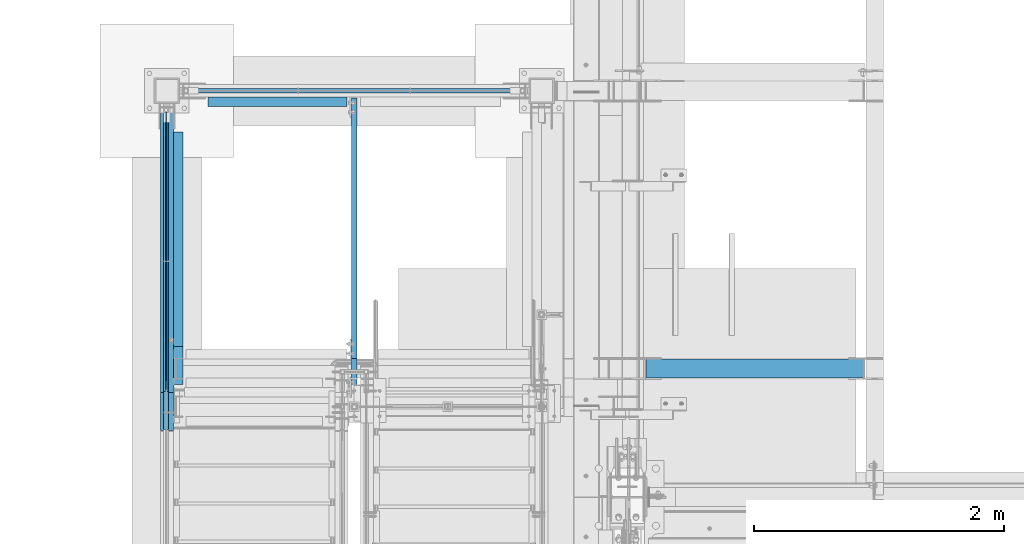
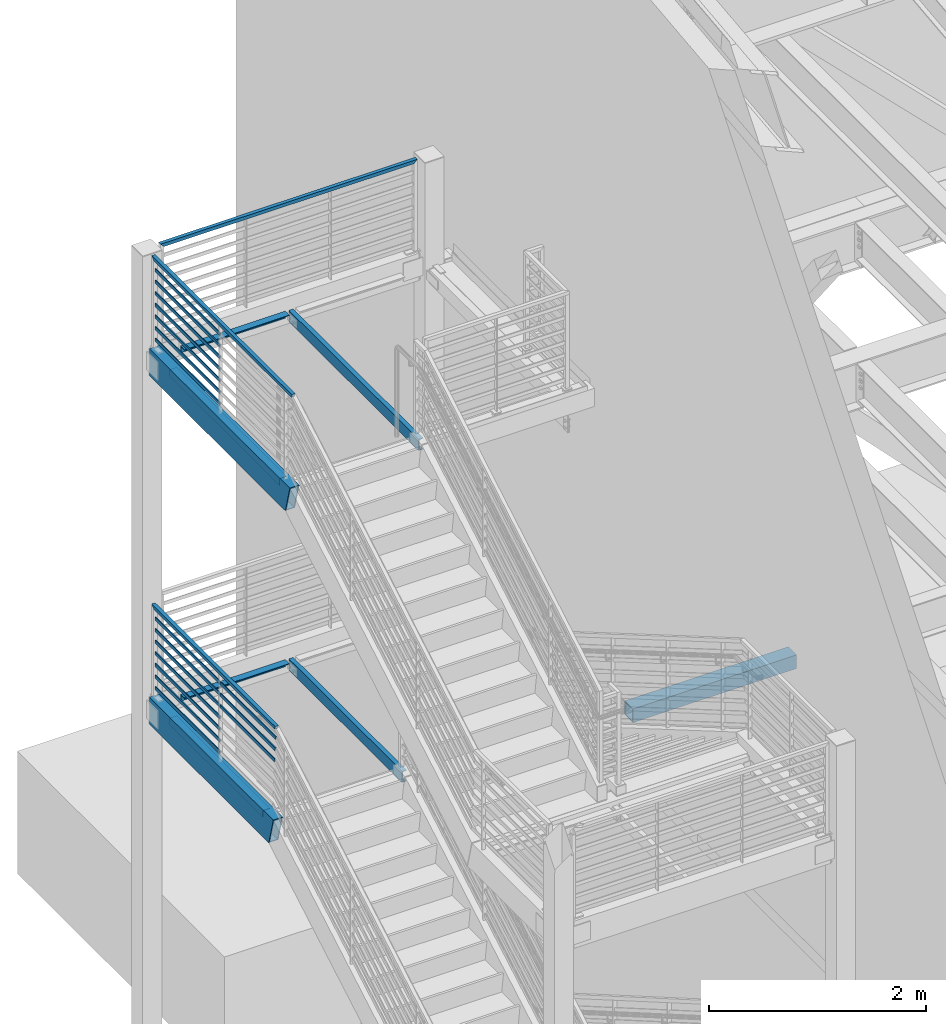
# One storey, part 764 of 1179: 29 beams, 10 elements without a shape of their own.
"""IFC2X3 building model written with IfcOpenShell, lengths in millimetres."""

from ifc_helpers import new_model, si_unit, frame, origin_with_axes, place, context, subcontext, project, spatial, faceted_brep, material, type_object, element, aggregate, save


model = new_model("IFC2X3")

# Units and contexts
model_context = context("Model", 3, precision=1e-05, world=origin_with_axes())
body_context = subcontext(model_context, "Body", "Model", "MODEL_VIEW")
ifc_project = project(units=[si_unit("LENGTHUNIT", "METRE", prefix="MILLI"), si_unit("AREAUNIT", "SQUARE_METRE"), si_unit("VOLUMEUNIT", "CUBIC_METRE"), si_unit("MASSUNIT", "GRAM", prefix="KILO"), si_unit("TIMEUNIT", "SECOND"), si_unit("PLANEANGLEUNIT", "RADIAN"), si_unit("SOLIDANGLEUNIT", "STERADIAN"), si_unit("THERMODYNAMICTEMPERATUREUNIT", "DEGREE_CELSIUS"), si_unit("LUMINOUSINTENSITYUNIT", "LUMEN")], contexts=[model_context])

# Site, building, storey
site_placement = place(None, origin_with_axes())
site = spatial("IfcSite", under=ifc_project, at=site_placement, CompositionType="ELEMENT")
building_placement = place(site_placement, origin_with_axes())
building = spatial("IfcBuilding", under=site, at=building_placement, Name="Undefined", CompositionType="ELEMENT")
storey_placement = place(building_placement, origin_with_axes())
storey = spatial("IfcBuildingStorey", under=building, at=storey_placement, Name="Undefined", CompositionType="ELEMENT", Elevation=0.0)

# Assembly, beams
assembly_1_placement = place(storey_placement, origin_with_axes())
assembly_1 = element("IfcElementAssembly", 1, at=assembly_1_placement, inside=storey, Name="GUARDRAIL", AssemblyPlace="NOTDEFINED", PredefinedType="RIGID_FRAME")
ifc_material_1 = material(Name="STEEL/A36")
beam_type_1 = type_object("IfcBeamType", PredefinedType="NOTDEFINED")
beam_1_placement = place(assembly_1_placement, frame((-3257.54999923555, 37490.4, 8305.78812688397), z_axis=(0.0, 0.0, 1.0), x_axis=(0.0, -1.0, 0.0)))
beam_1 = element("IfcBeam", 2, at=beam_1_placement, type_object=beam_type_1, material=ifc_material_1, Name="PLATE", context=body_context, shape_type="Brep", body=[
    faceted_brep([(19.0499992371956, 4.76249999999709, -19.0499999999993), (19.0499992371956, 4.76249999999709, 19.0499999999993), (1205.97083333334, 4.76249999999982, 19.0499999999993), (1205.97083333334, 4.76249999999982, -19.0499999999993), (19.0499992371956, -4.76249999999709, 19.0499999999993), (1205.97083333334, -4.76249999999982, 19.0499999999993), (19.0499992371956, -4.76249999999709, -19.0499999999993), (1205.97083333334, -4.76249999999982, -19.0499999999993)], [[[0, 1, 2, 3]], [[1, 4, 5, 2]], [[4, 6, 7, 5]], [[6, 0, 3, 7]], [[5, 7, 3, 2]], [[6, 4, 1, 0]]]),
])
beam_2_placement = place(assembly_1_placement, frame((-3257.54999923555, 37490.4, 8435.96312688397), z_axis=(0.0, 0.0, 1.0), x_axis=(0.0, -1.0, 0.0)))
beam_2 = element("IfcBeam", 3, at=beam_2_placement, type_object=beam_type_1, material=ifc_material_1, Name="PLATE", context=body_context, shape_type="Brep", body=[
    faceted_brep([(19.0499992371956, 4.76249999999709, -19.0499999999993), (19.0499992371956, 4.76249999999709, 19.0499999999993), (1205.97083333334, 4.76249999999982, 19.0499999999993), (1205.97083333334, 4.76249999999982, -19.0499999999993), (19.0499992371956, -4.76249999999709, 19.0499999999993), (1205.97083333334, -4.76249999999982, 19.0499999999993), (19.0499992371956, -4.76249999999709, -19.0499999999993), (1205.97083333334, -4.76249999999982, -19.0499999999993)], [[[0, 1, 2, 3]], [[1, 4, 5, 2]], [[4, 6, 7, 5]], [[6, 0, 3, 7]], [[5, 7, 3, 2]], [[6, 4, 1, 0]]]),
])
beam_3_placement = place(assembly_1_placement, frame((-3257.54999923555, 37490.4, 8566.13812688397), z_axis=(0.0, 0.0, 1.0), x_axis=(0.0, -1.0, 0.0)))
beam_3 = element("IfcBeam", 4, at=beam_3_placement, type_object=beam_type_1, material=ifc_material_1, Name="PLATE", context=body_context, shape_type="Brep", body=[
    faceted_brep([(19.0499992371956, 4.76249999999709, -19.0499999999993), (19.0499992371956, 4.76249999999709, 19.0499999999993), (1205.97083333334, 4.76249999999982, 19.0499999999993), (1205.97083333334, 4.76249999999982, -19.0499999999993), (19.0499992371956, -4.76249999999709, 19.0499999999993), (1205.97083333334, -4.76249999999982, 19.0499999999993), (19.0499992371956, -4.76249999999709, -19.0499999999993), (1205.97083333334, -4.76249999999982, -19.0499999999993)], [[[0, 1, 2, 3]], [[1, 4, 5, 2]], [[4, 6, 7, 5]], [[6, 0, 3, 7]], [[5, 7, 3, 2]], [[6, 4, 1, 0]]]),
])
beam_4_placement = place(assembly_1_placement, frame((-3257.54999923555, 37490.4, 8696.31312688397), z_axis=(0.0, 0.0, 1.0), x_axis=(0.0, -1.0, 0.0)))
beam_4 = element("IfcBeam", 5, at=beam_4_placement, type_object=beam_type_1, material=ifc_material_1, Name="PLATE", context=body_context, shape_type="Brep", body=[
    faceted_brep([(19.0499992371956, 4.76249999999709, -19.0499999999993), (19.0499992371956, 4.76249999999709, 19.0499999999993), (1205.97083333334, 4.76249999999982, 19.0499999999993), (1205.97083333334, 4.76249999999982, -19.0499999999993), (19.0499992371956, -4.76249999999709, 19.0499999999993), (1205.97083333334, -4.76249999999982, 19.0499999999993), (19.0499992371956, -4.76249999999709, -19.0499999999993), (1205.97083333334, -4.76249999999982, -19.0499999999993)], [[[0, 1, 2, 3]], [[1, 4, 5, 2]], [[4, 6, 7, 5]], [[6, 0, 3, 7]], [[5, 7, 3, 2]], [[6, 4, 1, 0]]]),
])
beam_5_placement = place(assembly_1_placement, frame((-3257.54999923555, 37490.4, 8826.48812688397), z_axis=(0.0, 0.0, 1.0), x_axis=(0.0, -1.0, 0.0)))
beam_5 = element("IfcBeam", 6, at=beam_5_placement, type_object=beam_type_1, material=ifc_material_1, Name="PLATE", context=body_context, shape_type="Brep", body=[
    faceted_brep([(19.0499992371956, 4.76249999999709, -19.0499999999993), (19.0499992371956, 4.76249999999709, 19.0499999999993), (1205.97083333334, 4.76249999999982, 19.0499999999993), (1205.97083333334, 4.76249999999982, -19.0499999999993), (19.0499992371956, -4.76249999999709, 19.0499999999993), (1205.97083333334, -4.76249999999982, 19.0499999999993), (19.0499992371956, -4.76249999999709, -19.0499999999993), (1205.97083333334, -4.76249999999982, -19.0499999999993)], [[[0, 1, 2, 3]], [[1, 4, 5, 2]], [[4, 6, 7, 5]], [[6, 0, 3, 7]], [[5, 7, 3, 2]], [[6, 4, 1, 0]]]),
])
beam_6_placement = place(assembly_1_placement, frame((-3257.54999923555, 37490.4, 8956.66312688397), z_axis=(0.0, 0.0, 1.0), x_axis=(0.0, -1.0, 0.0)))
beam_6 = element("IfcBeam", 7, at=beam_6_placement, type_object=beam_type_1, material=ifc_material_1, Name="PLATE", context=body_context, shape_type="Brep", body=[
    faceted_brep([(19.0499992371956, 4.76249999999709, -19.0499999999993), (19.0499992371956, 4.76249999999709, 19.0499999999993), (1205.97083333334, 4.76249999999982, 19.0499999999993), (1205.97083333334, 4.76249999999982, -19.0499999999993), (19.0499992371956, -4.76249999999709, 19.0499999999993), (1205.97083333334, -4.76249999999982, 19.0499999999993), (19.0499992371956, -4.76249999999709, -19.0499999999993), (1205.97083333334, -4.76249999999982, -19.0499999999993)], [[[0, 1, 2, 3]], [[1, 4, 5, 2]], [[4, 6, 7, 5]], [[6, 0, 3, 7]], [[5, 7, 3, 2]], [[6, 4, 1, 0]]]),
])
beam_7_placement = place(assembly_1_placement, frame((-3257.54999923555, 37490.3957801264, 9086.83812688397), z_axis=(0.0, 0.0, 1.0), x_axis=(0.0, -1.0, 0.0)))
beam_7 = element("IfcBeam", 8, at=beam_7_placement, type_object=beam_type_1, material=ifc_material_1, Name="PLATE", context=body_context, shape_type="Brep", body=[
    faceted_brep([(19.0457793613677, 4.76249999999982, -19.0499999999993), (19.0457793613677, 4.76249999999982, 19.0499999999993), (1205.96661345971, 4.76249999999982, 19.0499999999993), (1205.96661345971, 4.76249999999982, -19.0499999999993), (19.0457793613677, -4.76249999999982, 19.0499999999993), (1205.96661345971, -4.76249999999982, 19.0499999999993), (19.0457793613677, -4.76249999999982, -19.0499999999993), (1205.96661345971, -4.76249999999982, -19.0499999999993)], [[[0, 1, 2, 3]], [[1, 4, 5, 2]], [[4, 6, 7, 5]], [[6, 0, 3, 7]], [[5, 7, 3, 2]], [[6, 4, 1, 0]]]),
])

assembly_2_placement = place(storey_placement, origin_with_axes())
assembly_2 = element("IfcElementAssembly", 9, at=assembly_2_placement, inside=storey, Name="GUARDRAIL", AssemblyPlace="NOTDEFINED", PredefinedType="RIGID_FRAME")
beam_8_placement = place(assembly_2_placement, frame((-3257.54999923555, 37490.4, 4394.23611822362), z_axis=(0.0, 0.0, 1.0), x_axis=(0.0, -1.0, 0.0)))
beam_8 = element("IfcBeam", 10, at=beam_8_placement, type_object=beam_type_1, material=ifc_material_1, Name="PLATE", context=body_context, shape_type="Brep", body=[
    faceted_brep([(19.0499992371956, 4.76249999999709, -19.0499999999993), (19.0499992371956, 4.76249999999709, 19.0499999999993), (1205.97083333334, 4.76249999999982, 19.0499999999993), (1205.97083333334, 4.76249999999982, -19.0499999999993), (19.0499992371956, -4.76249999999709, 19.0499999999993), (1205.97083333334, -4.76249999999982, 19.0499999999993), (19.0499992371956, -4.76249999999709, -19.0499999999993), (1205.97083333334, -4.76249999999982, -19.0499999999993)], [[[0, 1, 2, 3]], [[1, 4, 5, 2]], [[4, 6, 7, 5]], [[6, 0, 3, 7]], [[5, 7, 3, 2]], [[6, 4, 1, 0]]]),
])
beam_9_placement = place(assembly_2_placement, frame((-3257.54999923555, 37490.4, 4524.41111822362), z_axis=(0.0, 0.0, 1.0), x_axis=(0.0, -1.0, 0.0)))
beam_9 = element("IfcBeam", 11, at=beam_9_placement, type_object=beam_type_1, material=ifc_material_1, Name="PLATE", context=body_context, shape_type="Brep", body=[
    faceted_brep([(19.0499992371956, 4.76249999999709, -19.0499999999993), (19.0499992371956, 4.76249999999709, 19.0499999999993), (1205.97083333334, 4.76249999999982, 19.0499999999993), (1205.97083333334, 4.76249999999982, -19.0499999999993), (19.0499992371956, -4.76249999999709, 19.0499999999993), (1205.97083333334, -4.76249999999982, 19.0499999999993), (19.0499992371956, -4.76249999999709, -19.0499999999993), (1205.97083333334, -4.76249999999982, -19.0499999999993)], [[[0, 1, 2, 3]], [[1, 4, 5, 2]], [[4, 6, 7, 5]], [[6, 0, 3, 7]], [[5, 7, 3, 2]], [[6, 4, 1, 0]]]),
])
beam_10_placement = place(assembly_2_placement, frame((-3257.54999923555, 37490.4, 4654.58611822362), z_axis=(0.0, 0.0, 1.0), x_axis=(0.0, -1.0, 0.0)))
beam_10 = element("IfcBeam", 12, at=beam_10_placement, type_object=beam_type_1, material=ifc_material_1, Name="PLATE", context=body_context, shape_type="Brep", body=[
    faceted_brep([(19.0499992371956, 4.76249999999709, -19.0499999999993), (19.0499992371956, 4.76249999999709, 19.0499999999993), (1205.97083333334, 4.76249999999982, 19.0499999999993), (1205.97083333334, 4.76249999999982, -19.0499999999993), (19.0499992371956, -4.76249999999709, 19.0499999999993), (1205.97083333334, -4.76249999999982, 19.0499999999993), (19.0499992371956, -4.76249999999709, -19.0499999999993), (1205.97083333334, -4.76249999999982, -19.0499999999993)], [[[0, 1, 2, 3]], [[1, 4, 5, 2]], [[4, 6, 7, 5]], [[6, 0, 3, 7]], [[5, 7, 3, 2]], [[6, 4, 1, 0]]]),
])
beam_11_placement = place(assembly_2_placement, frame((-3257.54999923555, 37490.4, 4784.76111822362), z_axis=(0.0, 0.0, 1.0), x_axis=(0.0, -1.0, 0.0)))
beam_11 = element("IfcBeam", 13, at=beam_11_placement, type_object=beam_type_1, material=ifc_material_1, Name="PLATE", context=body_context, shape_type="Brep", body=[
    faceted_brep([(19.0499992371956, 4.76249999999709, -19.0499999999993), (19.0499992371956, 4.76249999999709, 19.0499999999993), (1205.97083333334, 4.76249999999982, 19.0499999999993), (1205.97083333334, 4.76249999999982, -19.0499999999993), (19.0499992371956, -4.76249999999709, 19.0499999999993), (1205.97083333334, -4.76249999999982, 19.0499999999993), (19.0499992371956, -4.76249999999709, -19.0499999999993), (1205.97083333334, -4.76249999999982, -19.0499999999993)], [[[0, 1, 2, 3]], [[1, 4, 5, 2]], [[4, 6, 7, 5]], [[6, 0, 3, 7]], [[5, 7, 3, 2]], [[6, 4, 1, 0]]]),
])
beam_12_placement = place(assembly_2_placement, frame((-3257.54999923555, 36279.6666666664, 4914.93611822362), z_axis=(0.0, 0.0, 1.0), x_axis=(0.0, -1.0, 0.0)))
beam_12 = element("IfcBeam", 14, at=beam_12_placement, type_object=beam_type_1, material=ifc_material_1, Name="PLATE", context=body_context, shape_type="Brep", body=[
    faceted_brep([(4.76250000197615, 4.76249999999999, -19.0500000000002), (4.76250000197615, 4.76249999999999, 19.0500000000002), (1011.51926962293, 4.76249999999982, 19.0500000000002), (1001.28526268196, 4.76249999999982, -19.0500000000002), (4.76250000197615, -4.76249999999999, 19.0500000000002), (1011.51926962293, -4.76249999999982, 19.0500000000002), (4.76250000197615, -4.76249999999999, -19.0500000000002), (1001.28526268196, -4.76249999999982, -19.0500000000002)], [[[0, 1, 2, 3]], [[1, 4, 5, 2]], [[4, 6, 7, 5]], [[6, 0, 3, 7]], [[5, 7, 3, 2]], [[6, 4, 1, 0]]]),
])
beam_13_placement = place(assembly_2_placement, frame((-3257.54999923555, 37490.4, 4914.93611822362), z_axis=(0.0, 0.0, 1.0), x_axis=(0.0, -1.0, 0.0)))
beam_13 = element("IfcBeam", 15, at=beam_13_placement, type_object=beam_type_1, material=ifc_material_1, Name="PLATE", context=body_context, shape_type="Brep", body=[
    faceted_brep([(19.0499992371956, 4.76249999999709, -19.0499999999993), (19.0499992371956, 4.76249999999709, 19.0499999999993), (1205.97083333334, 4.76249999999982, 19.0499999999993), (1205.97083333334, 4.76249999999982, -19.0499999999993), (19.0499992371956, -4.76249999999709, 19.0499999999993), (1205.97083333334, -4.76249999999982, 19.0499999999993), (19.0499992371956, -4.76249999999709, -19.0499999999993), (1205.97083333334, -4.76249999999982, -19.0499999999993)], [[[0, 1, 2, 3]], [[1, 4, 5, 2]], [[4, 6, 7, 5]], [[6, 0, 3, 7]], [[5, 7, 3, 2]], [[6, 4, 1, 0]]]),
])
beam_14_placement = place(assembly_2_placement, frame((-3257.54999923555, 36279.6666666664, 5045.11111822362), z_axis=(0.0, 0.0, 1.0), x_axis=(0.0, -1.0, 0.0)))
beam_14 = element("IfcBeam", 16, at=beam_14_placement, type_object=beam_type_1, material=ifc_material_1, Name="PLATE", context=body_context, shape_type="Brep", body=[
    faceted_brep([(4.76250000197615, 4.76249999999999, -19.0500000000002), (4.76250000197615, 4.76249999999999, 19.0500000000002), (1021.75327658655, 4.76249999999982, 19.0500000000002), (1011.51926964558, 4.76249999999982, -19.0500000000002), (4.76250000197615, -4.76249999999999, 19.0500000000002), (1021.75327658655, -4.76249999999982, 19.0500000000002), (4.76250000197615, -4.76249999999999, -19.0500000000002), (1011.51926964558, -4.76249999999982, -19.0500000000002)], [[[0, 1, 2, 3]], [[1, 4, 5, 2]], [[4, 6, 7, 5]], [[6, 0, 3, 7]], [[5, 7, 3, 2]], [[6, 4, 1, 0]]]),
])
beam_15_placement = place(assembly_2_placement, frame((-3257.54999923555, 37490.4, 5045.11111822362), z_axis=(0.0, 0.0, 1.0), x_axis=(0.0, -1.0, 0.0)))
beam_15 = element("IfcBeam", 17, at=beam_15_placement, type_object=beam_type_1, material=ifc_material_1, Name="PLATE", context=body_context, shape_type="Brep", body=[
    faceted_brep([(19.0499992371956, 4.76249999999709, -19.0499999999993), (19.0499992371956, 4.76249999999709, 19.0499999999993), (1205.97083333334, 4.76249999999982, 19.0499999999993), (1205.97083333334, 4.76249999999982, -19.0499999999993), (19.0499992371956, -4.76249999999709, 19.0499999999993), (1205.97083333334, -4.76249999999982, 19.0499999999993), (19.0499992371956, -4.76249999999709, -19.0499999999993), (1205.97083333334, -4.76249999999982, -19.0499999999993)], [[[0, 1, 2, 3]], [[1, 4, 5, 2]], [[4, 6, 7, 5]], [[6, 0, 3, 7]], [[5, 7, 3, 2]], [[6, 4, 1, 0]]]),
])
beam_16_placement = place(assembly_2_placement, frame((-3257.54999923555, 36279.6662171819, 5175.28611821831), z_axis=(0.0, 0.0, 1.0), x_axis=(0.0, -1.0, 0.0)))
beam_16 = element("IfcBeam", 18, at=beam_16_placement, type_object=beam_type_1, material=ifc_material_1, Name="PLATE", context=body_context, shape_type="Brep", body=[
    faceted_brep([(4.76205051524448, 4.76249999999982, -19.0500000000002), (4.76205051524448, 4.76249999999982, 19.0500000000002), (1031.98683409613, 4.76249999999982, 19.0500000000002), (1021.75282715516, 4.76249999999982, -19.0500000000002), (4.76205051524448, -4.76249999999982, 19.0500000000002), (1031.98683409613, -4.76249999999982, 19.0500000000002), (4.76205051524448, -4.76249999999982, -19.0500000000002), (1021.75282715516, -4.76249999999982, -19.0500000000002)], [[[0, 1, 2, 3]], [[1, 4, 5, 2]], [[4, 6, 7, 5]], [[6, 0, 3, 7]], [[5, 7, 3, 2]], [[6, 4, 1, 0]]]),
])
beam_17_placement = place(assembly_2_placement, frame((-3257.54999923555, 37490.3995505152, 5175.28611821831), z_axis=(0.0, 0.0, 1.0), x_axis=(0.0, -1.0, 0.0)))
beam_17 = element("IfcBeam", 19, at=beam_17_placement, type_object=beam_type_1, material=ifc_material_1, Name="PLATE", context=body_context, shape_type="Brep", body=[
    faceted_brep([(19.0495497502488, 4.76249999999982, -19.0500000000002), (19.0495497502488, 4.76249999999982, 19.0500000000002), (1205.97038384858, 4.76249999999982, 19.0500000000002), (1205.97038384858, 4.76249999999982, -19.0500000000002), (19.0495497502488, -4.76249999999982, 19.0500000000002), (1205.97038384858, -4.76249999999982, 19.0500000000002), (19.0495497502488, -4.76249999999982, -19.0500000000002), (1205.97038384858, -4.76249999999982, -19.0500000000002)], [[[0, 1, 2, 3]], [[1, 4, 5, 2]], [[4, 6, 7, 5]], [[6, 0, 3, 7]], [[5, 7, 3, 2]], [[6, 4, 1, 0]]]),
])

# Assembly, beam
assembly_3_placement = place(storey_placement, origin_with_axes())
assembly_3 = element("IfcElementAssembly", 20, at=assembly_3_placement, inside=storey, Name="GUARDRAIL", AssemblyPlace="NOTDEFINED", PredefinedType="RIGID_FRAME")
ifc_material_2 = material()
beam_type_2 = type_object("IfcBeamType", Name="HSS1-1/2X1-1/2X1/4", PredefinedType="NOTDEFINED")
beam_18_placement = place(assembly_3_placement, frame((-3098.8, 37642.8, 9213.90291935232), z_axis=(0.0, 0.0, 1.0), x_axis=(1.0, 0.0, 0.0)))
beam_18 = element("IfcBeam", 21, at=beam_18_placement, type_object=beam_type_2, material=ifc_material_2, Name="GUARDRAIL", ObjectType="HSS1-1/2X1-1/2X1/4", context=body_context, shape_type="Brep", body=[
    faceted_brep([(12.6999993300014, 12.6999993299978, -12.6999993299996), (12.6999993300014, -12.6999993299978, -12.6999993299996), (2679.70000067, -12.6999993299978, -12.6999993299996), (2679.70000067, 12.6999993299978, -12.6999993299996), (-12.6999993299983, -12.6999993299978, 12.6999993299996), (2705.09999933, -12.6999993299978, 12.6999993299996), (-12.6999993299983, 12.6999993299978, 12.6999993299996), (2705.09999933, 12.6999993299978, 12.6999993299996), (19.0499999999993, 19.0499992349996, -19.0499992350015), (-19.0499992350015, 19.0499992350015, 19.0499992349996), (2711.449999235, 19.0499992350015, 19.0499992349996), (2673.350000765, 19.0499992350015, -19.0499992349996), (-19.0499992350015, -19.0499992350015, 19.0499992349996), (2711.449999235, -19.0499992350015, 19.0499992349996), (19.0499999999993, -19.0499992349996, -19.0499992350015), (2673.350000765, -19.0499992350015, -19.0499992349996)], [[[0, 1, 2, 3]], [[1, 4, 5, 2]], [[4, 6, 7, 5]], [[6, 0, 3, 7]], [[8, 9, 10, 11]], [[9, 12, 13, 10]], [[12, 14, 15, 13]], [[14, 8, 11, 15]], [[13, 15, 11, 10], [5, 7, 3, 2]], [[14, 12, 9, 8], [6, 4, 1, 0]]]),
])
aggregate(assembly_3, [beam_18])

# Beam
beam_19_placement = place(assembly_1_placement, frame((-3257.54999923555, 37490.4, 9213.84999999969), z_axis=(0.0, -2.07719999962137e-05, 0.999999999784262), x_axis=(0.0, -0.999999999784262, -2.07719999957954e-05)))
beam_19 = element("IfcBeam", 22, at=beam_19_placement, type_object=beam_type_2, material=ifc_material_2, Name="GUARDRAIL", ObjectType="HSS1-1/2X1-1/2X1/4", context=body_context, shape_type="Brep", body=[
    faceted_brep([(12.7002631381256, 12.6999993300001, -12.6999993299942), (12.7002631381256, -12.6999993300001, -12.6999993299942), (2549.35759712131, -12.6999993300001, -12.6999993310856), (2549.35759712131, 12.6999993300001, -12.6999993310856), (-12.7002631368232, -12.6999993300001, 12.699999329996), (2556.22412326928, -12.6999993300001, 12.6999993288919), (-12.7002631368232, 12.6999993300001, 12.699999329996), (2556.22412326928, 12.6999993300001, 12.6999993288919), (19.0503949468693, 19.0499992350001, -19.0499992349942), (-19.0503949455669, 19.0499992350001, 19.049999234996), (2557.94075487116, 19.0499992350001, 19.0499992338882), (2547.64096551943, 19.0499992350001, -19.0499992360801), (-19.0503949455669, -19.0499992350001, 19.049999234996), (2557.94075487116, -19.0499992350001, 19.0499992338882), (19.0503949468693, -19.0499992350001, -19.0499992349942), (2547.64096551943, -19.0499992350001, -19.0499992360801)], [[[0, 1, 2, 3]], [[1, 4, 5, 2]], [[4, 6, 7, 5]], [[6, 0, 3, 7]], [[8, 9, 10, 11]], [[9, 12, 13, 10]], [[12, 14, 15, 13]], [[14, 8, 11, 15]], [[13, 15, 11, 10], [5, 7, 3, 2]], [[14, 12, 9, 8], [6, 4, 1, 0]]]),
])

aggregate(assembly_1, [beam_1, beam_2, beam_3, beam_4, beam_5, beam_6, beam_7, beam_19])

beam_20_placement = place(assembly_2_placement, frame((-3257.54999923555, 37490.4, 5302.30291846465), z_axis=(0.0, -2.35949999914737e-05, 0.999999999721638), x_axis=(0.0, -0.999999999721638, -2.35949999936324e-05)))
beam_20 = element("IfcBeam", 23, at=beam_20_placement, type_object=beam_type_2, material=ifc_material_2, Name="GUARDRAIL", ObjectType="HSS1-1/2X1-1/2X1/4", context=body_context, shape_type="Brep", body=[
    faceted_brep([(12.7002631381256, 12.6999993300001, -12.6999993299942), (12.7002631381256, -12.6999993300001, -12.6999993299942), (2244.48903430735, -12.6999993300001, -12.6999993303061), (2244.48903430735, 12.6999993300001, -12.6999993303061), (-12.7002631368232, -12.6999993300001, 12.699999329996), (2251.31138397926, -12.6999993300001, 12.699999329694), (-12.7002631368232, 12.6999993300001, 12.699999329996), (2251.31138397926, 12.6999993300001, 12.699999329694), (19.0504487350117, 19.0499992350001, -19.0499992350033), (-19.0504487251528, 19.0499992350001, 19.0499992350042), (2253.0169714617, 19.0499992350001, 19.049999234695), (2242.78344682491, 19.0499992350001, -19.0499992353061), (-19.0504487251528, -19.0499992350001, 19.0499992350042), (2253.0169714617, -19.0499992350001, 19.049999234695), (19.0504487350117, -19.0499992350001, -19.0499992350033), (2242.78344682491, -19.0499992350001, -19.0499992353061)], [[[0, 1, 2, 3]], [[1, 4, 5, 2]], [[4, 6, 7, 5]], [[6, 0, 3, 7]], [[8, 9, 10, 11]], [[9, 12, 13, 10]], [[12, 14, 15, 13]], [[14, 8, 11, 15]], [[13, 15, 11, 10], [5, 7, 3, 2]], [[14, 12, 9, 8], [6, 4, 1, 0]]]),
])

aggregate(assembly_2, [beam_8, beam_9, beam_10, beam_11, beam_12, beam_13, beam_14, beam_15, beam_16, beam_17, beam_20])

# Assembly, beam
assembly_4_placement = place(storey_placement, origin_with_axes())
assembly_4 = element("IfcElementAssembly", 24, at=assembly_4_placement, inside=storey, Name="STRINGER", AssemblyPlace="NOTDEFINED", PredefinedType="RIGID_FRAME")
beam_type_3 = type_object("IfcBeamType", Name="L3X3X1/4", PredefinedType="NOTDEFINED")
beam_21_placement = place(assembly_4_placement, frame((-3162.30000000004, 35293.3000000002, 8007.35), z_axis=(1.0, 0.0, 0.0), x_axis=(0.0, 1.0, 0.0)))
beam_21 = element("IfcBeam", 25, at=beam_21_placement, type_object=beam_type_3, material=ifc_material_1, Name="ANGLE", ObjectType="L3X3X1/4", context=body_context, shape_type="Brep", body=[
    faceted_brep([(0.0, 38.0999999999985, -38.0999999999999), (0.0, 38.0999999999985, 38.0999999999999), (2019.29999999993, 38.1000000000004, 38.0999999999999), (2019.29999999993, 38.1000000000004, -38.0999999999999), (0.0, 31.75, 38.1000000000004), (2019.29999999993, 31.75, 38.0999999999999), (0.0, 31.75, -31.75), (2019.29999999993, 31.75, -31.75), (0.0, -38.0999999999985, -31.75), (2019.29999999993, -38.1000000000004, -31.75), (0.0, -38.0999999999985, -38.0999999999999), (2019.29999999993, -38.1000000000004, -38.0999999999999)], [[[0, 1, 2, 3]], [[1, 4, 5, 2]], [[4, 6, 7, 5]], [[6, 8, 9, 7]], [[8, 10, 11, 9]], [[10, 0, 3, 11]], [[5, 7, 9, 11, 3, 2]], [[10, 8, 6, 4, 1, 0]]]),
])

assembly_5_placement = place(storey_placement, origin_with_axes())
assembly_5 = element("IfcElementAssembly", 26, at=assembly_5_placement, inside=storey, Name="STRINGER", AssemblyPlace="NOTDEFINED", PredefinedType="RIGID_FRAME")
beam_22_placement = place(assembly_5_placement, frame((-3162.29999997224, 35598.1000000018, 4095.75), z_axis=(1.0, 0.0, 0.0), x_axis=(0.0, 1.0, 0.0)))
beam_22 = element("IfcBeam", 27, at=beam_22_placement, type_object=beam_type_3, material=ifc_material_1, Name="ANGLE", ObjectType="L3X3X1/4", context=body_context, shape_type="Brep", body=[
    faceted_brep([(0.0, 38.0999999999985, -38.0999999999999), (0.0, 38.0999999999985, 38.0999999999999), (1714.49999999727, 38.1, 38.0999999999999), (1714.49999999727, 38.1, -38.1000000000004), (0.0, 31.75, 38.1000000000004), (1714.49999999727, 31.75, 38.0999999999999), (0.0, 31.75, -31.75), (1714.49999999727, 31.75, -31.75), (0.0, -38.0999999999985, -31.75), (1714.49999999727, -38.1, -31.75), (0.0, -38.0999999999985, -38.0999999999999), (1714.49999999727, -38.1, -38.1000000000004)], [[[0, 1, 2, 3]], [[1, 4, 5, 2]], [[4, 6, 7, 5]], [[6, 8, 9, 7]], [[8, 10, 11, 9]], [[10, 0, 3, 11]], [[5, 7, 9, 11, 3, 2]], [[10, 8, 6, 4, 1, 0]]]),
])

assembly_6_placement = place(storey_placement, origin_with_axes())
assembly_6 = element("IfcElementAssembly", 28, at=assembly_6_placement, inside=storey, Name="BEAM", AssemblyPlace="NOTDEFINED", PredefinedType="RIGID_FRAME")
beam_23_placement = place(assembly_6_placement, frame((-2921.0, 37553.9, 4095.75), z_axis=(0.0, -1.0, 0.0), x_axis=(1.0, 0.0, 0.0)))
beam_23 = element("IfcBeam", 29, at=beam_23_placement, type_object=beam_type_3, material=ifc_material_1, Name="ANGLE", ObjectType="L3X3X1/4", context=body_context, shape_type="Brep", body=[
    faceted_brep([(0.0, 38.0999999999985, -38.0999999999999), (0.0, 38.0999999999985, 38.0999999999999), (1109.6625, 38.0999999999985, 38.0999999999999), (1109.6625, 38.0999999999985, -38.0999999999999), (0.0, 31.75, 38.1000000000004), (1109.6625, 31.75, 38.0999999999999), (0.0, 31.75, -31.75), (1109.6625, 31.75, -31.75), (0.0, -38.0999999999985, -31.75), (1109.6625, -38.0999999999985, -31.75), (0.0, -38.0999999999985, -38.0999999999999), (1109.6625, -38.0999999999985, -38.0999999999999)], [[[0, 1, 2, 3]], [[1, 4, 5, 2]], [[4, 6, 7, 5]], [[6, 8, 9, 7]], [[8, 10, 11, 9]], [[10, 0, 3, 11]], [[5, 7, 9, 11, 3, 2]], [[10, 8, 6, 4, 1, 0]]]),
])
aggregate(assembly_6, [beam_23])

assembly_7_placement = place(storey_placement, origin_with_axes())
assembly_7 = element("IfcElementAssembly", 30, at=assembly_7_placement, inside=storey, Name="BEAM", AssemblyPlace="NOTDEFINED", PredefinedType="RIGID_FRAME")
beam_24_placement = place(assembly_7_placement, frame((-2921.0, 37553.9, 8007.35), z_axis=(0.0, -1.0, 0.0), x_axis=(1.0, 0.0, 0.0)))
beam_24 = element("IfcBeam", 31, at=beam_24_placement, type_object=beam_type_3, material=ifc_material_1, Name="ANGLE", ObjectType="L3X3X1/4", context=body_context, shape_type="Brep", body=[
    faceted_brep([(0.0, 38.0999999999985, -38.0999999999999), (0.0, 38.0999999999985, 38.0999999999999), (1109.6625, 38.0999999999985, 38.0999999999999), (1109.6625, 38.0999999999985, -38.0999999999999), (0.0, 31.75, 38.1000000000004), (1109.6625, 31.75, 38.0999999999999), (0.0, 31.75, -31.75), (1109.6625, 31.75, -31.75), (0.0, -38.0999999999985, -31.75), (1109.6625, -38.0999999999985, -31.75), (0.0, -38.0999999999985, -38.0999999999999), (1109.6625, -38.0999999999985, -38.0999999999999)], [[[0, 1, 2, 3]], [[1, 4, 5, 2]], [[4, 6, 7, 5]], [[6, 8, 9, 7]], [[8, 10, 11, 9]], [[10, 0, 3, 11]], [[5, 7, 9, 11, 3, 2]], [[10, 8, 6, 4, 1, 0]]]),
])
aggregate(assembly_7, [beam_24])

assembly_8_placement = place(storey_placement, origin_with_axes())
assembly_8 = element("IfcElementAssembly", 32, at=assembly_8_placement, inside=storey, Name="BEAM", AssemblyPlace="NOTDEFINED", PredefinedType="RIGID_FRAME")
beam_type_4 = type_object("IfcBeamType", Name="C5X9", PredefinedType="NOTDEFINED")
beam_25_placement = place(assembly_8_placement, frame((-1752.6, 35496.5000000019, 4070.35), z_axis=(0.0, 0.0, 1.0), x_axis=(0.0, 1.0, 0.0)))
beam_25 = element("IfcBeam", 33, at=beam_25_placement, type_object=beam_type_4, material=ifc_material_1, Name="BEAM", ObjectType="C5X9", context=body_context, shape_type="Brep", body=[
    faceted_brep([(6.35000000080618, 23.8125, -63.5), (6.35000000080618, 23.8125, 63.5), (2089.14999999807, 23.8125, 63.5), (2089.14999999807, 23.8125, -63.5), (6.35000000080618, -23.8125, 63.5), (2089.14999999807, -23.8125, 63.5), (6.35000000080618, -23.8125, 59.5296625000001), (2089.14999999807, -23.8125, 59.5296625000001), (6.35000000080618, 15.875, 52.9177250000002), (2089.14999999807, 15.875, 52.9177250000002), (6.35000000080618, 15.875, -52.9177249999998), (2089.14999999807, 15.875, -52.9177249999998), (6.35000000080618, -23.8125, -59.5296625000001), (2089.14999999807, -23.8125, -59.5296625000001), (6.35000000080618, -23.8125, -63.5), (2089.14999999807, -23.8125, -63.5)], [[[0, 1, 2, 3]], [[1, 4, 5, 2]], [[4, 6, 7, 5]], [[6, 8, 9, 7]], [[8, 10, 11, 9]], [[10, 12, 13, 11]], [[12, 14, 15, 13]], [[14, 0, 3, 15]], [[5, 7, 9, 11, 13, 15, 3, 2]], [[14, 12, 10, 8, 6, 4, 1, 0]]]),
])
aggregate(assembly_8, [beam_25])

assembly_9_placement = place(storey_placement, origin_with_axes())
assembly_9 = element("IfcElementAssembly", 34, at=assembly_9_placement, inside=storey, Name="BEAM", AssemblyPlace="NOTDEFINED", PredefinedType="RIGID_FRAME")
beam_26_placement = place(assembly_9_placement, frame((-1752.6, 35191.7, 7981.95), z_axis=(0.0, 0.0, 1.0), x_axis=(0.0, 1.0, 0.0)))
beam_26 = element("IfcBeam", 35, at=beam_26_placement, type_object=beam_type_4, material=ifc_material_1, Name="BEAM", ObjectType="C5X9", context=body_context, shape_type="Brep", body=[
    faceted_brep([(6.35000000080618, 23.8125, -63.5), (6.35000000080618, 23.8125, 63.5), (2393.95, 23.8125, 63.5), (2393.95, 23.8125, -63.5), (6.35000000080618, -23.8125, 63.5), (2393.95, -23.8125, 63.5), (6.35000000080618, -23.8125, 59.5296625000001), (2393.95, -23.8125, 59.5296625000001), (6.35000000080618, 15.875, 52.9177250000002), (2393.95, 15.875, 52.9177250000002), (6.35000000080618, 15.875, -52.9177249999998), (2393.95, 15.875, -52.9177250000002), (6.35000000080618, -23.8125, -59.5296625000001), (2393.95, -23.8125, -59.5296625000001), (6.35000000080618, -23.8125, -63.5), (2393.95, -23.8125, -63.5)], [[[0, 1, 2, 3]], [[1, 4, 5, 2]], [[4, 6, 7, 5]], [[6, 8, 9, 7]], [[8, 10, 11, 9]], [[10, 12, 13, 11]], [[12, 14, 15, 13]], [[14, 0, 3, 15]], [[5, 7, 9, 11, 13, 15, 3, 2]], [[14, 12, 10, 8, 6, 4, 1, 0]]]),
])
aggregate(assembly_9, [beam_26])

assembly_10_placement = place(storey_placement, origin_with_axes())
assembly_10 = element("IfcElementAssembly", 36, at=assembly_10_placement, inside=storey, Name="BEAM", AssemblyPlace="NOTDEFINED", PredefinedType="RIGID_FRAME")
beam_type_5 = type_object("IfcBeamType", Name="HSS6X6X3/8", PredefinedType="NOTDEFINED")
beam_27_placement = place(assembly_10_placement, frame((574.671571065937, 35420.3000000026, 4025.9), z_axis=(0.0, 0.0, 1.0), x_axis=(1.0, 0.0, 0.0)))
beam_27 = element("IfcBeam", 37, at=beam_27_placement, type_object=beam_type_5, material=ifc_material_2, Name="BEAM", ObjectType="HSS6X6X3/8", context=body_context, shape_type="Brep", body=[
    faceted_brep([(9.52499999999998, 66.6750000000029, -66.6750000000002), (9.52499999999998, -66.6750000000029, -66.6750000000002), (1746.24983077433, -66.6749999947569, -66.6750000000002), (1746.24983077472, 66.6750000052416, -66.6750000000002), (9.52499999999998, -66.6750000000029, 66.6750000000002), (1746.24983077433, -66.6749999947569, 66.6750000000002), (9.52499999999998, 66.6750000000029, 66.6750000000002), (1746.24983077472, 66.6750000052416, 66.6750000000002), (9.52499999999998, 76.1999999999971, -76.1999999999998), (9.52499999999998, 76.1999999999971, 76.1999999999998), (1746.24983077475, 76.2000000052431, 76.1999999999998), (1746.24983077475, 76.2000000052431, -76.1999999999998), (9.52499999999998, -76.1999999999971, 76.1999999999998), (1746.2498307743, -76.1999999947584, 76.1999999999998), (9.52499999999998, -76.1999999999971, -76.1999999999998), (1746.2498307743, -76.1999999947584, -76.1999999999998)], [[[0, 1, 2, 3]], [[1, 4, 5, 2]], [[4, 6, 7, 5]], [[6, 0, 3, 7]], [[8, 9, 10, 11]], [[9, 12, 13, 10]], [[12, 14, 15, 13]], [[14, 8, 11, 15]], [[13, 15, 11, 10], [5, 7, 3, 2]], [[14, 12, 9, 8], [6, 4, 1, 0]]]),
])
aggregate(assembly_10, [beam_27])

# Beam
beam_type_6 = type_object("IfcBeamType", Name="HSS12X4X3/8", PredefinedType="NOTDEFINED")
beam_28_placement = place(assembly_4_placement, frame((-3251.20000000776, 37249.1000000034, 8045.44999999831), z_axis=(0.0, 0.0, 1.0), x_axis=(0.0, -1.0, 0.0)))
beam_28 = element("IfcBeam", 38, at=beam_28_placement, type_object=beam_type_6, material=ifc_material_2, Name="STRINGER", ObjectType="HSS12X4X3/8", context=body_context, shape_type="Brep", body=[
    faceted_brep([(-257.175000001473, 41.2750000000001, -142.875), (-257.175000001473, -41.2750000000001, -142.875), (2245.30639370454, -41.2750000000001, -142.875), (2245.30639370454, 41.2750000000001, -142.875), (-257.175000001473, -41.2750000000001, 142.875), (2322.55866081814, -41.2750000000001, 142.875), (-257.175000001473, 41.2750000000001, 142.875), (2322.55866081814, 41.2750000000001, 142.875), (-257.175000001473, 50.8000000000002, -152.4), (-257.175000001473, 50.8000000000002, 152.4), (2325.13373638859, 50.8000000000002, 152.4), (2242.73131813408, 50.8000000000002, -152.4), (-257.175000001473, -50.8000000000002, 152.4), (2325.13373638859, -50.8000000000002, 152.4), (-257.175000001473, -50.8000000000002, -152.4), (2242.73131813408, -50.8000000000002, -152.4)], [[[0, 1, 2, 3]], [[1, 4, 5, 2]], [[4, 6, 7, 5]], [[6, 0, 3, 7]], [[8, 9, 10, 11]], [[9, 12, 13, 10]], [[12, 14, 15, 13]], [[14, 8, 11, 15]], [[13, 15, 11, 10], [5, 7, 3, 2]], [[14, 12, 9, 8], [6, 4, 1, 0]]]),
])

aggregate(assembly_4, [beam_21, beam_28])

beam_29_placement = place(assembly_5_placement, frame((-3251.19999996767, 37553.9000000068, 4133.84999999953), z_axis=(0.0, 0.0, 1.0), x_axis=(0.0, -1.0, 0.0)))
beam_29 = element("IfcBeam", 39, at=beam_29_placement, type_object=beam_type_6, material=ifc_material_2, Name="STRINGER", ObjectType="HSS12X4X3/8", context=body_context, shape_type="Brep", body=[
    faceted_brep([(47.6250000019281, 41.2750000000001, -142.875), (47.6250000019281, -41.2750000000001, -142.875), (2245.73178881747, -41.2750000000001, -142.875), (2245.73178881747, 41.2750000000001, -142.875), (47.6250000019281, -41.2750000000001, 142.875), (2322.48684087476, -41.2750000000001, 142.875), (47.6250000019281, 41.2750000000001, 142.875), (2322.48684087476, 41.2750000000001, 142.875), (47.6250000019281, 50.8000000000002, -152.4), (47.6250000019281, 50.8000000000002, 152.4), (2325.04534261001, 50.8000000000002, 152.4), (2243.17328708222, 50.8000000000002, -152.4), (47.6250000019281, -50.8000000000002, 152.4), (2325.04534261001, -50.8000000000002, 152.4), (47.6250000019281, -50.8000000000002, -152.4), (2243.17328708222, -50.8000000000002, -152.4)], [[[0, 1, 2, 3]], [[1, 4, 5, 2]], [[4, 6, 7, 5]], [[6, 0, 3, 7]], [[8, 9, 10, 11]], [[9, 12, 13, 10]], [[12, 14, 15, 13]], [[14, 8, 11, 15]], [[13, 15, 11, 10], [5, 7, 3, 2]], [[14, 12, 9, 8], [6, 4, 1, 0]]]),
])

aggregate(assembly_5, [beam_22, beam_29])

save(model, "model.ifc")
